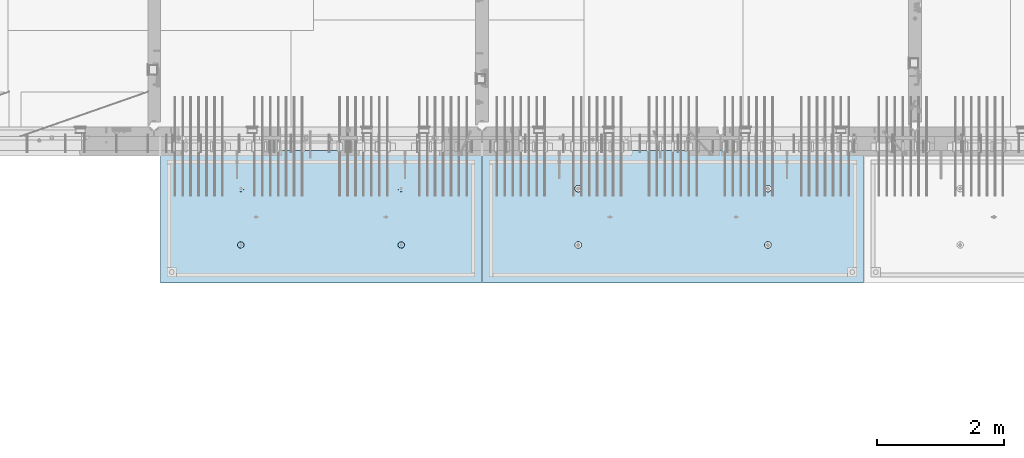
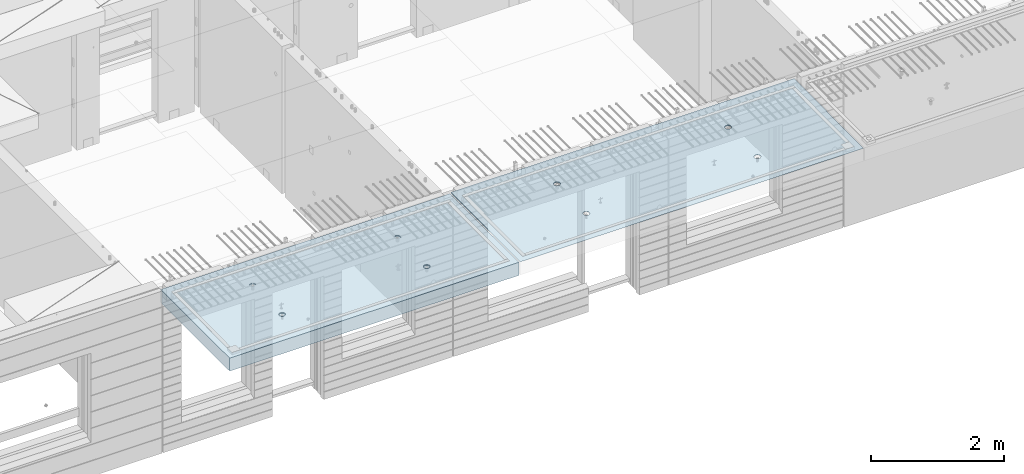
# One storey, part 194 of 334: 2 slabs, 2 elements without a shape of their own.
"""IFC2X3 building model written with IfcOpenShell, lengths in millimetres."""

from ifc_helpers import new_model, si_unit, frame, origin_with_axes, place, context, subcontext, project, spatial, faceted_brep, material, type_object, element, aggregate, save


model = new_model("IFC2X3")

# Units and contexts
model_context = context("Model", 3, precision=1e-05, world=origin_with_axes())
body_context = subcontext(model_context, "Body", "Model", "MODEL_VIEW")
ifc_project = project(units=[si_unit("LENGTHUNIT", "METRE", prefix="MILLI"), si_unit("AREAUNIT", "SQUARE_METRE"), si_unit("VOLUMEUNIT", "CUBIC_METRE"), si_unit("MASSUNIT", "GRAM", prefix="KILO"), si_unit("TIMEUNIT", "SECOND"), si_unit("PLANEANGLEUNIT", "RADIAN"), si_unit("SOLIDANGLEUNIT", "STERADIAN"), si_unit("THERMODYNAMICTEMPERATUREUNIT", "DEGREE_CELSIUS"), si_unit("LUMINOUSINTENSITYUNIT", "LUMEN")], contexts=[model_context])

# Site, building, storey
site_placement = place(None, origin_with_axes())
site = spatial("IfcSite", under=ifc_project, at=site_placement, CompositionType="ELEMENT")
building_placement = place(site_placement, origin_with_axes())
building = spatial("IfcBuilding", under=site, at=building_placement, CompositionType="ELEMENT")
storey_placement = place(building_placement, origin_with_axes())
storey = spatial("IfcBuildingStorey", under=building, at=storey_placement, Name="3", CompositionType="ELEMENT", Elevation=0.0)

# Assembly, slab
assembly_1_placement = place(storey_placement, origin_with_axes())
assembly_1 = element("IfcElementAssembly", 1, at=assembly_1_placement, inside=storey, AssemblyPlace="NOTDEFINED", PredefinedType="REINFORCEMENT_UNIT")
ifc_material = material(Name="CONCRETE/C35/45")
slab_type_1 = type_object("IfcSlabType", PredefinedType="NOTDEFINED")
slab_1_placement = place(assembly_1_placement, frame((27799.9998568133, 7629.99655735226, 90720.0), z_axis=(-1.11800000013248e-06, -0.999999999999375, 0.0), x_axis=(-0.999999999999093, 1.34699999998405e-06, 0.0)))
slab_1 = element("IfcSlab", 2, at=slab_1_placement, type_object=slab_type_1, material=ifc_material, PredefinedType="FLOOR", context=body_context, shape_type="Brep", body=[
    faceted_brep([(4430.38332613536, -4.08995228011918, 616.123557002266), (4431.90609271965, 10.0, 615.628782084005), (4439.08875686405, 10.0, 629.725594302773), (4437.8062304225, -3.95053914321761, 630.657402050439), (4450.27603094506, 10.0, 640.912894136913), (4449.35160622641, -3.83996043598745, 642.185252526786), (4464.3728266293, 10.0, 648.095590732159), (4463.88931892896, -3.76899254079035, 649.583668593681), (4479.99925133704, 10.0, 650.570591700976), (4479.99924953932, -3.74454363348195, 652.132471659324), (4495.6256817422, 10.0, 648.095626704194), (4496.1091860045, -3.76899218543258, 649.583705640341), (4509.72249396096, 10.0, 640.912962559792), (4510.64691570547, -3.83995975981816, 642.185323015524), (4520.9097937951, 10.0, 629.725688478787), (4522.19231800603, -3.95053821212787, 630.657499116635), (4528.09249039035, 10.0, 615.628892794549), (4529.6152557173, -4.08995118488383, 616.123671179757), (4530.56749135917, 10.0, 600.002468086805), (4532.18619485158, -4.24459073322942, 600.002469949934), (4528.09252636238, 10.0, 584.37603768165), (4529.64872932557, -4.39933455047139, 583.870398667863), (4520.90986221798, 10.0, 570.279225462882), (4522.24649000407, -4.53902051890327, 569.308110882728), (4509.72258813697, 10.0, 559.091925628744), (4510.70111430095, -4.6499364652409, 557.745103167879), (4495.62579245274, 10.0, 551.909229033497), (4496.142736776, -4.72117719323433, 550.318244231095), (4479.99936774499, 10.0, 549.43422806468), (4479.99936967367, -4.74573031402542, 547.758576892632), (4464.37293733984, 10.0, 551.909193061462), (4463.8559966665, -4.72117755009094, 550.318207030491), (4450.27612512107, 10.0, 559.091857205865), (4449.29760201216, -4.64993714379671, 557.745032430054), (4439.08882528693, 10.0, 570.279131286869), (4437.75219965053, -4.53902145239408, 569.308013567449), (4431.90612869169, 10.0, 584.375926971106), (4430.34992677396, -4.39933564719104, 583.87028433643), (4429.43112772287, 10.0, 600.002351678851), (4427.81242409951, -4.24459188559558, 600.002349815723), (0.0, 10.0, 0.0), (0.0, -10.0, 0.0), (0.000819232023786753, 10.0, 2085.00366210937), (5980.0, 10.0, -2.4019755073823e-09), (5980.0, -10.0, -2.4019755073823e-09), (5980.0009765625, 10.0, 2085.00366210937), (1450.3499233011, -4.39936856077111, 583.866853138679), (1451.90612877595, 10.0, 584.37249692914), (1449.43112780714, 10.0, 599.998921636884), (1447.81242044485, -4.24462478808709, 599.998919773752), (1457.75219670802, -4.53905437597132, 569.304581326389), (1459.0888253712, 10.0, 570.275701244902), (1469.29759989681, -4.64997007531929, 557.741599360567), (1470.27612520534, 10.0, 559.088427163899), (1483.85599559418, -4.7212104867067, 550.31477342891), (1484.3729374241, 10.0, 551.905763019495), (1499.99936975794, -4.74576325241651, 547.755143107666), (1499.99936782926, 10.0, 549.430798022713), (1516.14273801685, -4.72121012986463, 550.314810629518), (1515.62579253701, 10.0, 551.905798991532), (1530.70111658485, -4.64996939677803, 557.741670098397), (1529.72258822124, 10.0, 559.088495586778), (1542.24649311513, -4.53905344249506, 569.304678641675), (1540.90986230225, 10.0, 570.275795420916), (1549.64873296696, -4.39936746405147, 583.866967470121), (1548.09252644665, 10.0, 584.372607639683), (1552.18619867476, -4.24462363570638, 599.999039907971), (1550.56749144343, 10.0, 599.999038044839), (1549.61525935629, -4.08998407628678, 616.120242292795), (1548.09249047462, 10.0, 615.625462752582), (1542.19232111321, -3.95057109353365, 630.654071270945), (1540.90979387937, 10.0, 629.72225843682), (1530.64691798548, -3.83999263332225, 642.181895995745), (1529.72249404523, 10.0, 640.909532517825), (1516.10918724295, -3.76902505384351, 649.580279150618), (1515.62568182647, 10.0, 648.092196662228), (1499.99924962358, -3.7445765001321, 652.129045352205), (1499.9992514213, 10.0, 650.56716165901), (1483.88931785903, -3.76902540921583, 649.580242103954), (1484.37282671356, 10.0, 648.092160690191), (1469.35160411493, -3.83999330949155, 642.181825507), (1470.27603102933, 10.0, 640.909464094946), (1457.80622748385, -3.9505720246525, 630.653974204743), (1459.08875694832, 10.0, 629.722164260806), (1450.3833226649, -4.08998517153668, 616.120128115297), (1451.90609280392, 10.0, 615.625352042039), (1450.18528173966, 4.08930273250735, 1468.81238974452), (1450.82407776805, 10.0, 1469.01994796889), (1448.29345879993, 10.0, 1484.99752828805), (1447.63943102495, 4.24455558012414, 1484.99752753526), (1457.61190709188, 3.94915737991687, 1454.20221107617), (1458.16818327555, 10.0, 1454.60637035917), (1469.19529226424, 3.83787679090165, 1442.60118929624), (1469.60688310596, 10.0, 1443.16769686061), (1483.80158206606, 3.76640201332339, 1435.14993064656), (1484.02047762178, 10.0, 1435.82362453319), (1499.99806458492, 3.74176847410854, 1432.58187967207), (1499.99806376637, 10.0, 1433.29304234547), (1516.19454117951, 3.76640237134416, 1435.14996796955), (1515.97564408552, 10.0, 1435.82366131359), (1530.80081379559, 3.8378774716839, 1442.60126026678), (1530.38922169525, 10.0, 1443.16776682109), (1542.38417222175, 3.94915831647813, 1454.2023087116), (1541.82789519381, 10.0, 1454.6064666515), (1549.8107639085, 4.08930383282132, 1468.81250445209), (1549.17196752123, 10.0, 1469.02006116732), (1552.35657735256, 4.24455673628836, 1484.9976480647), (1551.70254970896, 10.0, 1484.99764731191), (1549.77718017658, 4.39970502781216, 1501.17188586406), (1549.17193074083, 10.0, 1500.97522763107), (1542.32982200517, 4.53957665037888, 1515.75352812725), (1541.82782523334, 10.0, 1515.38880524079), (1530.74643689407, 4.65051889081951, 1527.31927700612), (1530.38912540293, 10.0, 1526.82747873935), (1516.16088003051, 4.72171993891243, 1534.74199930817), (1515.9755308871, 10.0, 1534.17155106677), (1499.99794405534, 4.74624892331485, 1537.2991504223), (1499.99794474251, 10.0, 1536.70213325449), (1483.83501395426, 4.72171958237595, 1534.74196213963), (1484.02036442336, 10.0, 1534.17151428637), (1469.24947414505, 4.65051821242378, 1527.31920628548), (1469.60678681363, 10.0, 1526.82740877888), (1457.66611561777, 4.53957571620413, 1515.75343074172), (1458.16811331507, 10.0, 1515.38870894846), (1450.21879098044, 4.39970392896794, 1501.17177131094), (1450.82404098765, 10.0, 1500.97511443265), (4495.97553080284, 10.0, 1534.17498110874), (4496.16087879206, 4.72175280732336, 1534.74542579789), (4479.99794397108, 4.746281789965, 1537.30257672942), (4479.99794465824, 10.0, 1536.70556329646), (4510.38912531866, 10.0, 1526.83090878132), (4510.74643461406, 4.65055176430906, 1527.3227040259), (4521.82782514907, 10.0, 1515.39223528276), (4522.32981889799, 4.53960953179921, 1515.75695597294), (4529.17193065656, 10.0, 1500.97865767303), (4529.77717653759, 4.39973791921511, 1501.17531475103), (4531.70254962468, 10.0, 1485.00107735388), (4532.35657352936, 4.24458963877987, 1485.00107810666), (4529.17196743696, 10.0, 1469.02349120928), (4529.8107602671, 4.08933674640139, 1468.81593564983), (4521.82789510954, 10.0, 1454.60989669347), (4522.38416911069, 3.94919124005537, 1454.20574095265), (4510.38922161098, 10.0, 1443.17119686305), (4510.8008115117, 3.83791040322103, 1442.60469333626), (4495.97564400126, 10.0, 1435.82709135556), (4496.19453993865, 3.76643530797446, 1435.15340157113), (4479.99806368211, 10.0, 1433.29647238744), (4479.99806450065, 3.74180141248507, 1432.58531345704), (4464.02047753751, 10.0, 1435.82705457516), (4463.80158313838, 3.76643494995369, 1435.15336424814), (4449.60688302169, 10.0, 1443.17112690258), (4449.19529437959, 3.83790972242423, 1442.60462236572), (4438.16818319128, 10.0, 1454.60980040114), (4437.61191003439, 3.94919030349411, 1454.20564331723), (4430.82407768378, 10.0, 1469.02337801086), (4430.18528521251, 4.08933564607287, 1468.81582094227), (4437.66611855642, 4.53960859763902, 1515.75685858742), (4449.24947625653, 4.65055108592787, 1527.32263330526), (4463.83501502419, 4.72175245078688, 1534.74538862936), (4427.63943467959, 4.24458848261565, 1485.00095757723), (4430.2187944509, 4.39973682038544, 1501.17520019791), (4464.02036433909, 10.0, 1534.17494432834), (4449.60678672936, 10.0, 1526.83083882084), (4438.1681132308, 10.0, 1515.39213899043), (4430.82404090338, 10.0, 1500.97854447461), (4428.29345871566, 10.0, 1485.00095833002)], [[[0, 1, 2, 3]], [[3, 2, 4, 5]], [[5, 4, 6, 7]], [[7, 6, 8, 9]], [[10, 11, 9, 8]], [[12, 13, 11, 10]], [[14, 15, 13, 12]], [[16, 17, 15, 14]], [[18, 19, 17, 16]], [[20, 21, 19, 18]], [[22, 23, 21, 20]], [[24, 25, 23, 22]], [[26, 27, 25, 24]], [[27, 26, 28, 29]], [[29, 28, 30, 31]], [[31, 30, 32, 33]], [[33, 32, 34, 35]], [[35, 34, 36, 37]], [[37, 36, 38, 39]], [[39, 38, 1, 0]], [[40, 41, 42]], [[40, 43, 44, 41]], [[43, 45, 44]], [[46, 47, 48, 49]], [[50, 51, 47, 46]], [[52, 53, 51, 50]], [[54, 55, 53, 52]], [[56, 57, 55, 54]], [[58, 59, 57, 56]], [[59, 58, 60, 61]], [[61, 60, 62, 63]], [[63, 62, 64, 65]], [[65, 64, 66, 67]], [[67, 66, 68, 69]], [[69, 68, 70, 71]], [[71, 70, 72, 73]], [[73, 72, 74, 75]], [[75, 74, 76, 77]], [[78, 79, 77, 76]], [[80, 81, 79, 78]], [[82, 83, 81, 80]], [[84, 85, 83, 82]], [[49, 48, 85, 84]], [[86, 87, 88, 89]], [[90, 91, 87, 86]], [[92, 93, 91, 90]], [[94, 95, 93, 92]], [[96, 97, 95, 94]], [[98, 99, 97, 96]], [[100, 101, 99, 98]], [[101, 100, 102, 103]], [[103, 102, 104, 105]], [[105, 104, 106, 107]], [[107, 106, 108, 109]], [[109, 108, 110, 111]], [[111, 110, 112, 113]], [[113, 112, 114, 115]], [[115, 114, 116, 117]], [[117, 116, 118, 119]], [[120, 121, 119, 118]], [[122, 123, 121, 120]], [[124, 125, 123, 122]], [[89, 88, 125, 124]], [[126, 127, 128, 129]], [[130, 131, 127, 126]], [[132, 133, 131, 130]], [[134, 135, 133, 132]], [[136, 137, 135, 134]], [[138, 139, 137, 136]], [[140, 141, 139, 138]], [[142, 143, 141, 140]], [[143, 142, 144, 145]], [[145, 144, 146, 147]], [[147, 146, 148, 149]], [[149, 148, 150, 151]], [[151, 150, 152, 153]], [[153, 152, 154, 155]], [[41, 44, 45, 42], [3, 5, 7, 9, 11, 13, 15, 17, 19, 21, 23, 25, 27, 29, 31, 33, 35, 37, 39, 0], [156, 157, 158, 128, 127, 131, 133, 135, 137, 139, 141, 143, 145, 147, 149, 151, 153, 155, 159, 160], [122, 120, 118, 116, 114, 112, 110, 108, 106, 104, 102, 100, 98, 96, 94, 92, 90, 86, 89, 124], [82, 80, 78, 76, 74, 72, 70, 68, 66, 64, 62, 60, 58, 56, 54, 52, 50, 46, 49, 84]], [[129, 128, 158, 161]], [[157, 162, 161, 158]], [[156, 163, 162, 157]], [[160, 164, 163, 156]], [[159, 165, 164, 160]], [[155, 154, 165, 159]], [[43, 40, 42, 45], [34, 32, 30, 28, 26, 24, 22, 20, 18, 16, 14, 12, 10, 8, 6, 4, 2, 1, 38, 36], [152, 150, 148, 146, 144, 142, 140, 138, 136, 134, 132, 130, 126, 129, 161, 162, 163, 164, 165, 154], [91, 93, 95, 97, 99, 101, 103, 105, 107, 109, 111, 113, 115, 117, 119, 121, 123, 125, 88, 87], [51, 53, 55, 57, 59, 61, 63, 65, 67, 69, 71, 73, 75, 77, 79, 81, 83, 85, 48, 47]]]),
])
aggregate(assembly_1, [slab_1])

assembly_2_placement = place(storey_placement, origin_with_axes())
assembly_2 = element("IfcElementAssembly", 3, at=assembly_2_placement, inside=storey, AssemblyPlace="NOTDEFINED", PredefinedType="REINFORCEMENT_UNIT")
slab_type_2 = type_object("IfcSlabType", PredefinedType="NOTDEFINED")
slab_2_placement = place(assembly_2_placement, frame((21799.9998568133, 7629.99655735226, 90590.0), z_axis=(-1.11800000013248e-06, -0.999999999999375, 0.0), x_axis=(-0.999999999999093, 1.34699999998405e-06, 0.0)))
slab_2 = element("IfcSlab", 4, at=slab_2_placement, type_object=slab_type_2, material=ifc_material, PredefinedType="FLOOR", context=body_context, shape_type="Brep", body=[
    faceted_brep([(1275.44980856604, -115.0, 552.444777751491), (1289.3882117606, -115.0, 559.546772887367), (1300.44978375459, -115.0, 570.608375101608), (1307.55174081072, -115.0, 584.54679769877), (1309.9988938901, -115.0, 599.997650760343), (1307.551698599, -115.0, 615.448497136235), (1300.44970346313, -115.0, 629.3869003308), (1289.38810124889, -115.0, 640.448472324786), (1275.44967865172, -115.0, 647.550429380917), (1259.99882559015, -115.0, 649.997582460297), (1244.54797921425, -115.0, 647.550387169195), (1230.60957601969, -115.0, 640.44839203332), (1219.54800402571, -115.0, 629.386789819078), (1212.44604696957, -115.0, 615.448367221916), (1209.9988938902, -115.0, 599.997514160343), (1212.4460891813, -115.0, 584.546667784451), (1219.54808431717, -115.0, 570.608264589886), (1230.60968653141, -115.0, 559.546692595902), (1244.54810912857, -115.0, 552.444735539769), (1259.99896219015, -115.0, 549.99758246039), (1219.08841602657, -120.0, 570.274295068632), (1211.90571640051, -120.0, 584.371089208588), (1230.27571826597, -120.0, 559.087023392896), (1244.37253202901, -120.0, 551.904362279308), (1259.99896296629, -120.0, 549.429400642209), (1275.6253871419, -120.0, 551.904404970708), (1289.72218128186, -120.0, 559.087104596764), (1300.9094529576, -120.0, 570.274406836168), (1308.09211407118, -120.0, 584.371220599207), (1310.56707570828, -120.0, 599.99765153648), (1308.09207137979, -120.0, 615.624075712098), (1300.90937175373, -120.0, 629.720869852056), (1289.72206951433, -120.0, 640.90814152779), (1275.62525575129, -120.0, 648.090802641378), (1259.99882481401, -120.0, 650.565764278478), (1244.37240063839, -120.0, 648.090759949978), (1230.27560649844, -120.0, 640.908060323922), (1219.0883348227, -120.0, 629.72075808452), (1211.90567370912, -120.0, 615.623944321479), (1209.43071207202, -120.0, 599.997513384206), (0.000328360383718973, -120.0, 2085.00366210938), (5040.00048828125, -120.0, 2085.00366210938), (5040.00048828125, 120.0, 2085.00366210938), (0.000328360383718973, 120.0, 2085.00366210938), (5040.0, -120.0, -2.18278728425503e-09), (5040.0, 120.0, -2.18278728425503e-09), (-7.27595761418343e-12, -120.0, -9.09494701772928e-13), (-7.27595761418343e-12, 120.0, -9.09494701772928e-13), (1275.44859965604, -105.0, 1437.44477775066), (1289.38700285061, -105.0, 1444.54677288654), (1300.44857484459, -105.0, 1455.60837510078), (1307.55053190072, -105.0, 1469.54679769794), (1309.9976849801, -105.0, 1484.99765075952), (1307.550489689, -105.0, 1500.44849713541), (1300.44849455313, -105.0, 1514.38690032997), (1289.38689233888, -105.0, 1525.44847232396), (1275.44846974172, -105.0, 1532.55042938009), (1259.99761668015, -105.0, 1534.99758245947), (1244.54677030425, -105.0, 1532.55038716837), (1230.60836710969, -105.0, 1525.44839203249), (1219.5467951157, -105.0, 1514.38678981825), (1212.44483805958, -105.0, 1500.44836722109), (1209.99768498019, -105.0, 1484.99751415952), (1212.44488027129, -105.0, 1469.54666778362), (1219.54687540717, -105.0, 1455.60826458906), (1230.60847762142, -105.0, 1444.54669259508), (1244.54690021857, -105.0, 1437.44473553894), (1259.99775328015, -105.0, 1434.99758245956), (1210.82376192895, -120.0, 1469.01993205604), (1208.29313952565, -120.0, 1484.99751183111), (1218.16787053537, -120.0, 1454.60635602529), (1229.60657282509, -120.0, 1443.16768498606), (1244.02016891989, -120.0, 1435.82361575756), (1259.99775560856, -120.0, 1433.29303700502), (1275.97533538363, -120.0, 1435.82365940832), (1290.38891141437, -120.0, 1443.16776801474), (1301.82758245361, -120.0, 1454.60647030446), (1309.17165168211, -120.0, 1469.02006639925), (1311.70223043464, -120.0, 1484.99765308793), (1309.17160803135, -120.0, 1500.975232863), (1301.82749942493, -120.0, 1515.38880889374), (1290.3887971352, -120.0, 1526.82747993297), (1275.97520104041, -120.0, 1534.17154916147), (1259.99761435174, -120.0, 1536.70212791401), (1244.02003457667, -120.0, 1534.17150551072), (1229.60645854592, -120.0, 1526.8273969043), (1218.16778750669, -120.0, 1515.38869461457), (1210.82371827819, -120.0, 1500.97509851978), (3795.4485995714, -105.0, 1437.44822013263), (3809.38700276596, -105.0, 1444.55021526851), (3820.44857475995, -105.0, 1455.61181748275), (3827.55053181608, -105.0, 1469.55024007991), (3829.99768489545, -105.0, 1485.00109314148), (3827.55048960436, -105.0, 1500.45193951738), (3820.44849446848, -105.0, 1514.39034271194), (3809.38689225424, -105.0, 1525.45191470593), (3795.44846965708, -105.0, 1532.55387176206), (3779.9976165955, -105.0, 1535.00102484144), (3764.54677021961, -105.0, 1532.55382955034), (3750.60836702505, -105.0, 1525.45183441446), (3739.54679503106, -105.0, 1514.39023220022), (3732.44483797493, -105.0, 1500.45180960306), (3729.99768489555, -105.0, 1485.00095654148), (3732.44488018665, -105.0, 1469.55011016559), (3739.54687532252, -105.0, 1455.61170697103), (3750.60847753677, -105.0, 1444.55013497704), (3764.54690013393, -105.0, 1437.44817792091), (3779.9977531955, -105.0, 1435.00102484153), (3730.82376184431, -120.0, 1469.023374438), (3728.293139441, -120.0, 1485.00095421308), (3738.16787045072, -120.0, 1454.60979840726), (3749.60657274045, -120.0, 1443.17112736803), (3764.02016883524, -120.0, 1435.82705813953), (3779.99775552391, -120.0, 1433.29647938699), (3795.97533529898, -120.0, 1435.82710179029), (3810.38891132972, -120.0, 1443.1712103967), (3821.82758236896, -120.0, 1454.60991268643), (3829.17165159746, -120.0, 1469.02350878122), (3831.70223035, -120.0, 1485.00109546989), (3829.1716079467, -120.0, 1500.97867524497), (3821.82749934028, -120.0, 1515.39225127571), (3810.38879705056, -120.0, 1526.83092231494), (3795.97520095576, -120.0, 1534.17499154344), (3779.99761426709, -120.0, 1536.70557029598), (3764.02003449202, -120.0, 1534.17494789268), (3749.60645846128, -120.0, 1526.83083928627), (3738.16778742204, -120.0, 1515.39213699654), (3730.82371819355, -120.0, 1500.97854090175), (3795.4498084814, -115.0, 552.448220133458), (3809.38821167596, -115.0, 559.550215269334), (3820.44978366995, -115.0, 570.611817483575), (3827.55174072608, -115.0, 584.550240080738), (3829.99889380546, -115.0, 600.00109314231), (3827.55169851435, -115.0, 615.451939518203), (3820.44970337848, -115.0, 629.390342712767), (3809.38810116424, -115.0, 640.451914706753), (3795.44967856708, -115.0, 647.553871762884), (3779.9988255055, -115.0, 650.001024842264), (3764.54797912961, -115.0, 647.553829551163), (3750.60957593505, -115.0, 640.451834415288), (3739.54800394106, -115.0, 629.390232201046), (3732.44604688493, -115.0, 615.451809603883), (3729.99889380555, -115.0, 600.000956542311), (3732.44608909665, -115.0, 584.550110166418), (3739.54808423252, -115.0, 570.611706971854), (3750.60968644677, -115.0, 559.550134977869), (3764.54810904393, -115.0, 552.448177921737), (3779.9989621055, -115.0, 550.001024842357), (3731.90571631587, -120.0, 584.374531590555), (3729.43071198737, -120.0, 600.000955766174), (3739.08841594193, -120.0, 570.277737450599), (3750.27571818133, -120.0, 559.090465774863), (3764.37253194437, -120.0, 551.907804661275), (3779.99896288164, -120.0, 549.432843024176), (3795.62538705726, -120.0, 551.907847352675), (3809.72218119721, -120.0, 559.090546978732), (3820.90945287295, -120.0, 570.277849218135), (3828.09211398654, -120.0, 584.374662981175), (3830.56707562364, -120.0, 600.001093918447), (3828.09207129514, -120.0, 615.627518094066), (3820.90937166908, -120.0, 629.724312234023), (3809.72206942968, -120.0, 640.911583909758), (3795.62525566664, -120.0, 648.094245023345), (3779.99882472937, -120.0, 650.569206660445), (3764.37240055375, -120.0, 648.094202331945), (3750.27560641379, -120.0, 640.911502705889), (3739.08833473806, -120.0, 629.724200466487), (3731.90567362447, -120.0, 615.627386703446)], [[[0, 1, 2, 3, 4, 5, 6, 7, 8, 9, 10, 11, 12, 13, 14, 15, 16, 17, 18, 19]], [[20, 16, 15, 21]], [[22, 17, 16, 20]], [[23, 18, 17, 22]], [[24, 19, 18, 23]], [[25, 0, 19, 24]], [[26, 1, 0, 25]], [[27, 2, 1, 26]], [[28, 3, 2, 27]], [[29, 4, 3, 28]], [[30, 5, 4, 29]], [[31, 6, 5, 30]], [[32, 7, 6, 31]], [[33, 8, 7, 32]], [[34, 9, 8, 33]], [[35, 10, 9, 34]], [[36, 11, 10, 35]], [[37, 12, 11, 36]], [[38, 13, 12, 37]], [[39, 14, 13, 38]], [[21, 15, 14, 39]], [[40, 41, 42, 43]], [[41, 44, 45, 42]], [[44, 46, 47, 45]], [[42, 45, 47, 43]], [[46, 40, 43, 47]], [[48, 49, 50, 51, 52, 53, 54, 55, 56, 57, 58, 59, 60, 61, 62, 63, 64, 65, 66, 67]], [[68, 63, 62, 69]], [[70, 64, 63, 68]], [[71, 65, 64, 70]], [[72, 66, 65, 71]], [[73, 67, 66, 72]], [[74, 48, 67, 73]], [[75, 49, 48, 74]], [[76, 50, 49, 75]], [[77, 51, 50, 76]], [[78, 52, 51, 77]], [[79, 53, 52, 78]], [[80, 54, 53, 79]], [[81, 55, 54, 80]], [[82, 56, 55, 81]], [[83, 57, 56, 82]], [[84, 58, 57, 83]], [[85, 59, 58, 84]], [[86, 60, 59, 85]], [[87, 61, 60, 86]], [[69, 62, 61, 87]], [[88, 89, 90, 91, 92, 93, 94, 95, 96, 97, 98, 99, 100, 101, 102, 103, 104, 105, 106, 107]], [[108, 103, 102, 109]], [[110, 104, 103, 108]], [[111, 105, 104, 110]], [[112, 106, 105, 111]], [[113, 107, 106, 112]], [[114, 88, 107, 113]], [[115, 89, 88, 114]], [[116, 90, 89, 115]], [[117, 91, 90, 116]], [[118, 92, 91, 117]], [[119, 93, 92, 118]], [[120, 94, 93, 119]], [[121, 95, 94, 120]], [[122, 96, 95, 121]], [[123, 97, 96, 122]], [[124, 98, 97, 123]], [[125, 99, 98, 124]], [[126, 100, 99, 125]], [[127, 101, 100, 126]], [[109, 102, 101, 127]], [[128, 129, 130, 131, 132, 133, 134, 135, 136, 137, 138, 139, 140, 141, 142, 143, 144, 145, 146, 147]], [[148, 143, 142, 149]], [[150, 144, 143, 148]], [[151, 145, 144, 150]], [[152, 146, 145, 151]], [[153, 147, 146, 152]], [[154, 128, 147, 153]], [[155, 129, 128, 154]], [[156, 130, 129, 155]], [[157, 131, 130, 156]], [[158, 132, 131, 157]], [[159, 133, 132, 158]], [[160, 134, 133, 159]], [[161, 135, 134, 160]], [[162, 136, 135, 161]], [[163, 137, 136, 162]], [[164, 138, 137, 163]], [[165, 139, 138, 164]], [[166, 140, 139, 165]], [[167, 141, 140, 166]], [[149, 142, 141, 167]], [[44, 41, 40, 46], [37, 36, 35, 34, 33, 32, 31, 30, 29, 28, 27, 26, 25, 24, 23, 22, 20, 21, 39, 38], [166, 165, 164, 163, 162, 161, 160, 159, 158, 157, 156, 155, 154, 153, 152, 151, 150, 148, 149, 167], [126, 125, 124, 123, 122, 121, 120, 119, 118, 117, 116, 115, 114, 113, 112, 111, 110, 108, 109, 127], [86, 85, 84, 83, 82, 81, 80, 79, 78, 77, 76, 75, 74, 73, 72, 71, 70, 68, 69, 87]]]),
])
aggregate(assembly_2, [slab_2])

save(model, "model.ifc")
